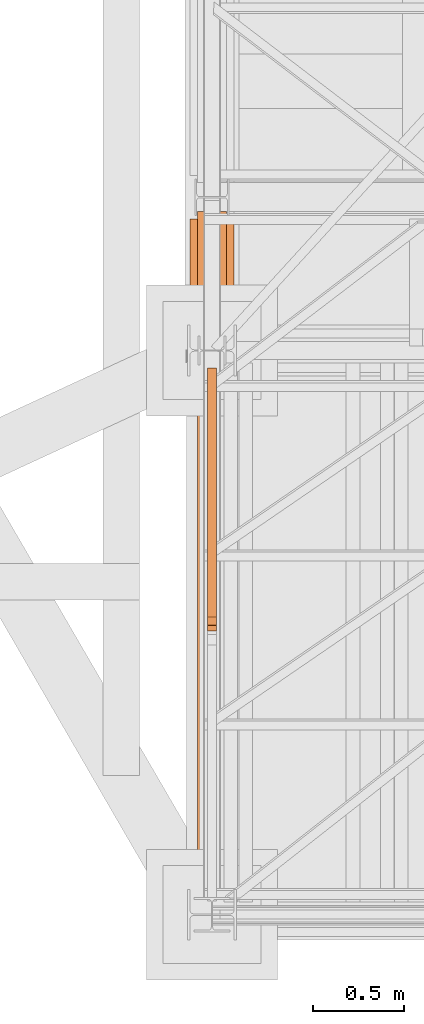
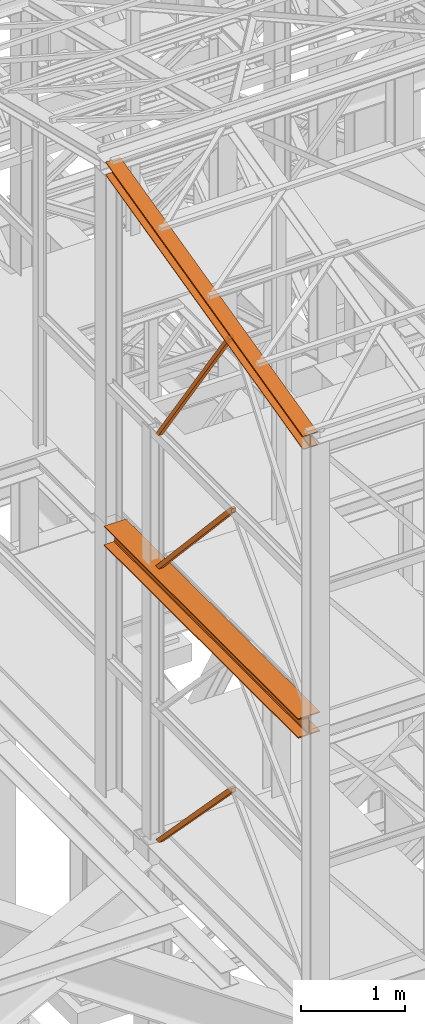
# One storey, part 12 of 208: 7 proxies.
"""IFC2X3 building model written with IfcOpenShell, lengths in millimetres."""

from ifc_helpers import new_model, entity, si_unit, converted_unit, frame, origin, origin_with_axes, place, context, subcontext, project, spatial, faceted_brep, element, save


model = new_model("IFC2X3")

# Units and contexts
model_context = context("Model", 3, precision=1e-05, world=origin())
plan_context = context("Plan", 3, precision=1e-05, world=origin())
body_context = subcontext(model_context, "Body", "Model", "MODEL_VIEW")
ifc_project = project(units=[si_unit("LENGTHUNIT", "METRE", prefix="MILLI"), converted_unit("PLANEANGLEUNIT", "DEGREE", entity("IfcPlaneAngleMeasure", 0.0174532925199433), si_unit("PLANEANGLEUNIT", "RADIAN"), dimensions=[0, 0, 0, 0, 0, 0, 0]), si_unit("AREAUNIT", "SQUARE_METRE"), si_unit("VOLUMEUNIT", "CUBIC_METRE")], contexts=[model_context, plan_context])

# Building, storey
building_placement = place(None, origin())
building = spatial("IfcBuilding", under=ifc_project, at=building_placement, CompositionType="COMPLEX")
storey_placement = place(building_placement, origin_with_axes())
storey = spatial("IfcBuildingStorey", under=building, at=storey_placement, Name="Geschoss", CompositionType="ELEMENT")

# Proxies
proxy_1_placement = place(storey_placement, frame((1078.254963760292, -25052.57438554952, 8254.989997913835), z_axis=(0.0, 0.0, 1.0), x_axis=(1.0, 0.0, 0.0)))
element("IfcBuildingElementProxy", 1, at=proxy_1_placement, inside=storey, context=body_context, shape_type="Brep", body=[
    faceted_brep([(240.0100095367423, 0.01000000000203727, 0.01000000000021828), (240.0100095367423, 3715.009990463259, 0.01000000000203727), (0.0100000000009004, 3715.009990463259, 0.01000000000021828), (0.009999999999990905, 0.01000000000203727, 0.01000000000021828), (0.009999999999990905, 0.01000000000203727, 0.01000000000021828), (0.0100000000009004, 3715.009990463259, 0.01000000000021828), (0.0100000000009004, 3715.009990463259, 12.0100019669535), (0.009999999999990905, 0.01000000000203727, 12.0100019669535), (0.009999999999990905, 0.01000000000203727, 12.0100019669535), (0.0100000000009004, 3715.009990463259, 12.0100019669535), (95.26000303983778, 3715.009990463259, 12.0100019669535), (95.26000303983687, 0.01000000000203727, 12.0100019669535), (95.26000303983687, 0.01000000000203727, 12.0100019669535), (95.26000303983778, 3715.009990463259, 12.0100019669535), (106.1284490099558, 3715.009990463259, 14.18530328035376), (106.1284490099549, 0.01000000000203727, 14.18530328035376), (106.1284490099549, 0.01000000000203727, 14.18530328035376), (106.1284490099558, 3715.009990463259, 14.18530328035376), (114.0846986493477, 3715.009990463259, 22.14155478239081), (114.0846986493468, 0.01000000000203727, 22.14155478239081), (114.0846986493468, 0.01000000000203727, 22.14155478239081), (114.0846986493477, 3715.009990463259, 22.14155478239081), (116.2600046193609, 3715.009990463259, 33.00999982118628), (116.26000461936, 0.01000000000203727, 33.00999982118628), (116.26000461936, 0.01000000000203727, 33.00999982118628), (116.2600046193609, 3715.009990463259, 33.00999982118628), (116.2600046193609, 3715.009990463259, 197.0100043511357), (116.26000461936, 0.01000000000203727, 197.0100043511357), (116.26000461936, 0.01000000000203727, 197.0100043511357), (116.2600046193609, 3715.009990463259, 197.0100043511357), (114.0846986493477, 3715.009990463259, 207.8784493899311), (114.0846986493468, 0.01000000000203727, 207.8784493899311), (114.0846986493468, 0.01000000000203727, 207.8784493899311), (114.0846986493477, 3715.009990463259, 207.8784493899311), (106.1284490099558, 3715.009990463259, 215.8347008919682), (106.1284490099549, 0.01000000000203727, 215.8347008919682), (106.1284490099549, 0.01000000000203727, 215.8347008919682), (106.1284490099558, 3715.009990463259, 215.8347008919682), (95.26000303983778, 3715.009990463259, 218.0100022053684), (95.26000303983778, 0.01000000000203727, 218.0100022053684), (95.26000303983778, 0.01000000000203727, 218.0100022053684), (95.26000303983778, 3715.009990463259, 218.0100022053684), (0.0100000000009004, 3715.009990463259, 218.0100022053684), (0.009999999999990905, 0.01000000000203727, 218.0100022053684), (0.009999999999990905, 0.01000000000203727, 218.0100022053684), (0.0100000000009004, 3715.009990463259, 218.0100022053684), (0.0100000000009004, 3715.009990463259, 230.0100041723235), (0.009999999999990905, 0.01000000000203727, 230.0100041723235), (0.009999999999990905, 0.01000000000203727, 230.0100041723235), (0.0100000000009004, 3715.009990463259, 230.0100041723235), (240.0100095367432, 3715.009990463259, 230.0100041723217), (240.0100095367423, 0.01000000000203727, 230.0100041723217), (240.0100095367423, 0.01000000000203727, 230.0100041723217), (240.0100095367432, 3715.009990463259, 230.0100041723217), (240.0100095367432, 3715.009990463259, 218.0100022053684), (240.0100095367423, 0.01000000000203727, 218.0100022053684), (240.0100095367423, 0.01000000000203727, 218.0100022053684), (240.0100095367432, 3715.009990463259, 218.0100022053684), (144.7600064969063, 3715.009990463259, 218.0100022053684), (144.7600064969054, 0.01000000000203727, 218.0100022053684), (144.7600064969054, 0.01000000000203727, 218.0100022053684), (144.7600064969063, 3715.009990463259, 218.0100022053684), (133.8915605267873, 3715.009990463259, 215.8347008919682), (133.8915605267873, 0.01000000000203727, 215.8347008919682), (133.8915605267873, 0.01000000000203727, 215.8347008919682), (133.8915605267873, 3715.009990463259, 215.8347008919682), (125.9353108873954, 3715.009990463259, 207.8784493899311), (125.9353108873954, 0.01000000000203727, 207.8784493899311), (125.9353108873954, 0.01000000000203727, 207.8784493899311), (125.9353108873954, 3715.009990463259, 207.8784493899311), (123.7600049173841, 3715.009990463259, 197.0100043511338), (123.7600049173823, 0.00999999999839929, 197.0100043511357), (123.7600049173823, 0.00999999999839929, 197.0100043511357), (123.7600049173841, 3715.009990463259, 197.0100043511338), (123.7600049173832, 3715.009990463259, 33.00999982118628), (123.7600049173823, 0.01000000000203727, 33.00999982118628), (123.7600049173823, 0.01000000000203727, 33.00999982118628), (123.7600049173832, 3715.009990463259, 33.00999982118628), (125.9353108873963, 3715.009990463259, 22.14155478239081), (125.9353108873954, 0.01000000000203727, 22.14155478239081), (125.9353108873954, 0.01000000000203727, 22.14155478239081), (125.9353108873963, 3715.009990463259, 22.14155478239081), (133.8915605267882, 3715.009990463259, 14.18530328035376), (133.8915605267873, 0.01000000000203727, 14.18530328035376), (133.8915605267873, 0.01000000000203727, 14.18530328035376), (133.8915605267882, 3715.009990463259, 14.18530328035376), (144.7600064969063, 3715.009990463259, 12.0100019669535), (144.7600064969054, 0.01000000000203727, 12.0100019669535), (144.7600064969054, 0.01000000000203727, 12.0100019669535), (144.7600064969063, 3715.009990463259, 12.0100019669535), (240.0100095367432, 3715.009990463259, 12.0100019669535), (240.0100095367423, 0.01000000000203727, 12.0100019669535), (240.0100095367423, 0.01000000000203727, 12.0100019669535), (240.0100095367432, 3715.009990463259, 12.0100019669535), (240.0100095367423, 3715.009990463259, 0.01000000000203727), (240.0100095367423, 0.01000000000203727, 0.01000000000021828), (0.009999999999990905, 0.01000000000203727, 0.01000000000021828), (0.009999999999990905, 0.01000000000203727, 12.0100019669535), (95.26000303983687, 0.01000000000203727, 12.0100019669535), (106.1284490099549, 0.01000000000203727, 14.18530328035376), (114.0846986493468, 0.01000000000203727, 22.14155478239081), (116.26000461936, 0.01000000000203727, 33.00999982118628), (116.26000461936, 0.01000000000203727, 197.0100043511357), (114.0846986493468, 0.01000000000203727, 207.8784493899311), (106.1284490099549, 0.01000000000203727, 215.8347008919682), (95.26000303983778, 0.01000000000203727, 218.0100022053684), (0.009999999999990905, 0.01000000000203727, 218.0100022053684), (0.009999999999990905, 0.01000000000203727, 230.0100041723235), (240.0100095367423, 0.01000000000203727, 230.0100041723217), (240.0100095367423, 0.01000000000203727, 218.0100022053684), (144.7600064969054, 0.01000000000203727, 218.0100022053684), (133.8915605267873, 0.01000000000203727, 215.8347008919682), (125.9353108873954, 0.01000000000203727, 207.8784493899311), (123.7600049173823, 0.00999999999839929, 197.0100043511357), (123.7600049173823, 0.01000000000203727, 33.00999982118628), (125.9353108873954, 0.01000000000203727, 22.14155478239081), (133.8915605267873, 0.01000000000203727, 14.18530328035376), (144.7600064969054, 0.01000000000203727, 12.0100019669535), (240.0100095367423, 0.01000000000203727, 12.0100019669535), (240.0100095367423, 0.01000000000203727, 0.01000000000021828), (0.0100000000009004, 3715.009990463259, 0.01000000000021828), (240.0100095367423, 3715.009990463259, 0.01000000000203727), (240.0100095367432, 3715.009990463259, 12.0100019669535), (144.7600064969063, 3715.009990463259, 12.0100019669535), (133.8915605267882, 3715.009990463259, 14.18530328035376), (125.9353108873963, 3715.009990463259, 22.14155478239081), (123.7600049173832, 3715.009990463259, 33.00999982118628), (123.7600049173841, 3715.009990463259, 197.0100043511338), (125.9353108873954, 3715.009990463259, 207.8784493899311), (133.8915605267873, 3715.009990463259, 215.8347008919682), (144.7600064969063, 3715.009990463259, 218.0100022053684), (240.0100095367432, 3715.009990463259, 218.0100022053684), (240.0100095367432, 3715.009990463259, 230.0100041723217), (0.0100000000009004, 3715.009990463259, 230.0100041723235), (0.0100000000009004, 3715.009990463259, 218.0100022053684), (95.26000303983778, 3715.009990463259, 218.0100022053684), (106.1284490099558, 3715.009990463259, 215.8347008919682), (114.0846986493477, 3715.009990463259, 207.8784493899311), (116.2600046193609, 3715.009990463259, 197.0100043511357), (116.2600046193609, 3715.009990463259, 33.00999982118628), (114.0846986493477, 3715.009990463259, 22.14155478239081), (106.1284490099558, 3715.009990463259, 14.18530328035376), (95.26000303983778, 3715.009990463259, 12.0100019669535), (0.0100000000009004, 3715.009990463259, 12.0100019669535)], [[[0, 1, 2, 3]], [[4, 5, 6, 7]], [[8, 9, 10, 11]], [[12, 13, 14, 15]], [[16, 17, 18, 19]], [[20, 21, 22, 23]], [[24, 25, 26, 27]], [[28, 29, 30, 31]], [[32, 33, 34, 35]], [[36, 37, 38, 39]], [[40, 41, 42, 43]], [[44, 45, 46, 47]], [[48, 49, 50, 51]], [[52, 53, 54, 55]], [[56, 57, 58, 59]], [[60, 61, 62, 63]], [[64, 65, 66, 67]], [[68, 69, 70, 71]], [[72, 73, 74, 75]], [[76, 77, 78, 79]], [[80, 81, 82, 83]], [[84, 85, 86, 87]], [[88, 89, 90, 91]], [[92, 93, 94, 95]], [[96, 97, 98, 99, 100, 101, 102, 103, 104, 105, 106, 107, 108, 109, 110, 111, 112, 113, 114, 115, 116, 117, 118, 119]], [[120, 121, 122, 123, 124, 125, 126, 127, 128, 129, 130, 131, 132, 133, 134, 135, 136, 137, 138, 139, 140, 141, 142, 143]]], orient=[[False], [False], [False], [False], [False], [False], [False], [False], [False], [False], [False], [False], [False], [False], [False], [False], [False], [False], [False], [False], [False], [False], [False], [False], [False], [False]]),
])
proxy_2_placement = place(storey_placement, frame((1118.254966591503, -25077.57437538435, 11628.70515179705), z_axis=(0.0, 0.0, 1.0), x_axis=(1.0, 0.0, 0.0)))
element("IfcBuildingElementProxy", 2, at=proxy_2_placement, inside=storey, context=body_context, shape_type="Brep", body=[
    faceted_brep([(160.0100113248898, 3780.009979404025, 1074.775244917653), (160.0100113248795, 0.00999999999839929, 156.4315054631916), (0.009999999999990905, 0.00999999999839929, 156.4315054631916), (0.01000000000681212, 3780.009979404025, 1074.775244917653), (0.01000000000681212, 3780.009979404025, 1074.775244917653), (0.009999999999990905, 0.00999999999839929, 156.4315054631916), (0.009999999999990905, 0.00999999999839929, 147.1697029728093), (0.01000000000681212, 3780.009979404025, 1065.513442427271), (0.01000000000681212, 3780.009979404025, 1065.513442427271), (0.009999999999990905, 0.00999999999839929, 147.1697029728093), (62.01000457465648, 0.00999999999839929, 147.1697029728093), (62.01000457466284, 3780.009979404025, 1065.513442427271), (62.01000457466284, 3780.009979404025, 1065.513442427271), (62.01000457465648, 0.00999999999839929, 147.1697029728093), (69.77318079977863, 0.00999999999839929, 145.5707163655079), (69.77318079978863, 3780.009979404025, 1063.914455819968), (69.77318079978863, 3780.009979404025, 1063.914455819968), (69.77318079977863, 0.00999999999839929, 145.5707163655079), (75.45621545821064, 0.00999999999839929, 139.7223691397903), (75.4562154582211, 3780.009979404025, 1058.066108594254), (75.4562154582211, 3780.009979404025, 1058.066108594254), (75.45621545821064, 0.00999999999839929, 139.7223691397903), (77.01000563636057, 0.00999999999839929, 131.7333744340358), (77.01000563637058, 3780.009979404025, 1050.077113888498), (77.01000563637058, 3780.009979404025, 1050.077113888498), (77.01000563636057, 0.00999999999839929, 131.7333744340358), (77.01000563636057, 0.00999999999839929, 24.70813486281259), (77.01000563637058, 3780.009979404025, 943.0518743172743), (77.01000563637058, 3780.009979404025, 943.0518743172743), (77.01000563636057, 0.00999999999839929, 24.70813486281259), (75.45621545821064, 0.00999999999839929, 16.71913632339965), (75.45621545822064, 3780.009979404025, 935.0628757778613), (75.45621545822064, 3780.009979404025, 935.0628757778613), (75.45621545821064, 0.00999999999839929, 16.71913632339965), (69.77318079977863, 0.00999999999839929, 10.87078909768752), (69.77318079978863, 3780.009979404025, 929.2145285521474), (69.77318079978863, 3780.009979404025, 929.2145285521474), (69.77318079977863, 0.00999999999839929, 10.87078909768752), (62.01000457465284, 0.00999999999839929, 9.27180249038247), (62.01000457466284, 3780.009979404025, 927.6155419448442), (62.01000457466284, 3780.009979404025, 927.6155419448442), (62.01000457465284, 0.00999999999839929, 9.27180249038247), (0.009999999999990905, 0.00999999999839929, 9.27180249038247), (0.01000000000681212, 3780.009979404025, 927.6155419448423), (0.01000000000681212, 3780.009979404025, 927.6155419448423), (0.009999999999990905, 0.00999999999839929, 9.27180249038247), (0.009999999999990905, 0.00999999999839929, 0.01000000000021828), (0.01000000000635737, 3780.009979404025, 918.3537394544601), (0.01000000000635737, 3780.009979404025, 918.3537394544601), (0.009999999999990905, 0.00999999999839929, 0.01000000000021828), (160.0100113248827, 0.00999999999839929, 0.01000000000021828), (160.0100113248898, 3780.009979404025, 918.3537394544619), (160.0100113248898, 3780.009979404025, 918.3537394544619), (160.0100113248827, 0.00999999999839929, 0.01000000000021828), (160.0100113248832, 0.00999999999839929, 9.27180249038065), (160.0100113248898, 3780.009979404025, 927.6155419448423), (160.0100113248898, 3780.009979404025, 927.6155419448423), (160.0100113248832, 0.00999999999839929, 9.27180249038065), (98.01000675022237, 0.00999999999839929, 9.27180249038247), (98.01000675023238, 3780.009979404025, 927.6155419448423), (98.01000675023238, 3780.009979404025, 927.6155419448423), (98.01000675022237, 0.00999999999839929, 9.27180249038247), (90.24683052509658, 0.00999999999839929, 10.87078909768752), (90.24683052510659, 3780.009979404025, 929.2145285521474), (90.24683052510659, 3780.009979404025, 929.2145285521474), (90.24683052509658, 0.00999999999839929, 10.87078909768752), (84.56379586666458, 0.00999999999839929, 16.71913632339783), (84.56379586667458, 3780.009979404025, 935.0628757778613), (84.56379586667458, 3780.009979404025, 935.0628757778613), (84.56379586666458, 0.00999999999839929, 16.71913632339783), (83.01000568851464, 0.00999999999839929, 24.70813486281077), (83.01000568852464, 3780.009979404025, 943.0518743172743), (83.01000568852464, 3780.009979404025, 943.0518743172743), (83.01000568851464, 0.00999999999839929, 24.70813486281077), (83.0100056885151, 0.00999999999839929, 131.733374434034), (83.01000568852464, 3780.009979404025, 1050.077113888496), (83.01000568852464, 3780.009979404025, 1050.077113888496), (83.0100056885151, 0.00999999999839929, 131.733374434034), (84.56379586666458, 0.00999999999839929, 139.7223691397903), (84.56379586667504, 3780.009979404025, 1058.066108594254), (84.56379586667504, 3780.009979404025, 1058.066108594254), (84.56379586666458, 0.00999999999839929, 139.7223691397903), (90.24683052509704, 0.00999999999839929, 145.5707163655079), (90.24683052510704, 3780.009979404025, 1063.914455819968), (90.24683052510704, 3780.009979404025, 1063.914455819968), (90.24683052509704, 0.00999999999839929, 145.5707163655079), (98.01000675022237, 0.00999999999839929, 147.1697029728093), (98.01000675023238, 3780.009979404025, 1065.513442427271), (98.01000675023238, 3780.009979404025, 1065.513442427271), (98.01000675022237, 0.00999999999839929, 147.1697029728093), (160.010011324883, 0.00999999999839929, 147.1697029728093), (160.0100113248898, 3780.009979404025, 1065.513442427271), (160.0100113248898, 3780.009979404025, 1065.513442427271), (160.010011324883, 0.00999999999839929, 147.1697029728093), (160.0100113248795, 0.00999999999839929, 156.4315054631916), (160.0100113248898, 3780.009979404025, 1074.775244917653), (0.01000000000681212, 3780.009979404025, 1074.775244917653), (0.01000000000681212, 3780.009979404025, 1065.513442427271), (62.01000457466284, 3780.009979404025, 1065.513442427271), (69.77318079978863, 3780.009979404025, 1063.914455819968), (75.4562154582211, 3780.009979404025, 1058.066108594254), (77.01000563637058, 3780.009979404025, 1050.077113888498), (77.01000563637058, 3780.009979404025, 943.0518743172743), (75.45621545822064, 3780.009979404025, 935.0628757778613), (69.77318079978863, 3780.009979404025, 929.2145285521474), (62.01000457466284, 3780.009979404025, 927.6155419448442), (0.01000000000681212, 3780.009979404025, 927.6155419448423), (0.01000000000635737, 3780.009979404025, 918.3537394544601), (160.0100113248898, 3780.009979404025, 918.3537394544619), (160.0100113248898, 3780.009979404025, 927.6155419448423), (98.01000675023238, 3780.009979404025, 927.6155419448423), (90.24683052510659, 3780.009979404025, 929.2145285521474), (84.56379586667458, 3780.009979404025, 935.0628757778613), (83.01000568852464, 3780.009979404025, 943.0518743172743), (83.01000568852464, 3780.009979404025, 1050.077113888496), (84.56379586667504, 3780.009979404025, 1058.066108594254), (90.24683052510704, 3780.009979404025, 1063.914455819968), (98.01000675023238, 3780.009979404025, 1065.513442427271), (160.0100113248898, 3780.009979404025, 1065.513442427271), (160.0100113248898, 3780.009979404025, 1074.775244917653), (160.0100113248795, 0.00999999999839929, 156.4315054631916), (160.010011324883, 0.00999999999839929, 147.1697029728093), (98.01000675022237, 0.00999999999839929, 147.1697029728093), (90.24683052509704, 0.00999999999839929, 145.5707163655079), (84.56379586666458, 0.00999999999839929, 139.7223691397903), (83.0100056885151, 0.00999999999839929, 131.733374434034), (83.01000568851464, 0.00999999999839929, 24.70813486281077), (84.56379586666458, 0.00999999999839929, 16.71913632339783), (90.24683052509658, 0.00999999999839929, 10.87078909768752), (98.01000675022237, 0.00999999999839929, 9.27180249038247), (160.0100113248832, 0.00999999999839929, 9.27180249038065), (160.0100113248827, 0.00999999999839929, 0.01000000000021828), (0.009999999999990905, 0.00999999999839929, 0.01000000000021828), (0.009999999999990905, 0.00999999999839929, 9.27180249038247), (62.01000457465284, 0.00999999999839929, 9.27180249038247), (69.77318079977863, 0.00999999999839929, 10.87078909768752), (75.45621545821064, 0.00999999999839929, 16.71913632339965), (77.01000563636057, 0.00999999999839929, 24.70813486281259), (77.01000563636057, 0.00999999999839929, 131.7333744340358), (75.45621545821064, 0.00999999999839929, 139.7223691397903), (69.77318079977863, 0.00999999999839929, 145.5707163655079), (62.01000457465648, 0.00999999999839929, 147.1697029728093), (0.009999999999990905, 0.00999999999839929, 147.1697029728093), (0.009999999999990905, 0.00999999999839929, 156.4315054631916)], [[[0, 1, 2, 3]], [[4, 5, 6, 7]], [[8, 9, 10, 11]], [[12, 13, 14, 15]], [[16, 17, 18, 19]], [[20, 21, 22, 23]], [[24, 25, 26, 27]], [[28, 29, 30, 31]], [[32, 33, 34, 35]], [[36, 37, 38, 39]], [[40, 41, 42, 43]], [[44, 45, 46, 47]], [[48, 49, 50, 51]], [[52, 53, 54, 55]], [[56, 57, 58, 59]], [[60, 61, 62, 63]], [[64, 65, 66, 67]], [[68, 69, 70, 71]], [[72, 73, 74, 75]], [[76, 77, 78, 79]], [[80, 81, 82, 83]], [[84, 85, 86, 87]], [[88, 89, 90, 91]], [[92, 93, 94, 95]], [[96, 97, 98, 99, 100, 101, 102, 103, 104, 105, 106, 107, 108, 109, 110, 111, 112, 113, 114, 115, 116, 117, 118, 119]], [[120, 121, 122, 123, 124, 125, 126, 127, 128, 129, 130, 131, 132, 133, 134, 135, 136, 137, 138, 139, 140, 141, 142, 143]]], orient=[[False], [False], [False], [False], [False], [False], [False], [False], [False], [False], [False], [False], [False], [False], [False], [False], [False], [False], [False], [False], [False], [False], [False], [False], [False], [False]]),
])
proxy_3_placement = place(storey_placement, frame((1173.25497001878, -23609.99467518261, 5284.990005364415), z_axis=(0.0, 0.0, 1.0), x_axis=(1.0, 0.0, 0.0)))
element("IfcBuildingElementProxy", 3, at=proxy_3_placement, inside=storey, context=body_context, shape_type="Brep", body=[
    faceted_brep([(0.0100000000009004, 0.2928158898466791, 1428.866375912856), (50.01000074505896, 0.2928158898466791, 1428.866375912854), (50.01000074505805, 1388.6428749638, 0.01000000000021828), (0.009999999999990905, 1388.6428749638, 0.01000000000021828), (50.01000074505896, 32.15127611343269, 1474.917439180826), (50.01000074505805, 1452.430287281288, 0.01000000000021828), (50.01000074505805, 1388.6428749638, 0.01000000000021828), (50.01000074505896, 0.2928158898466791, 1428.866375912854), (50.01000074505896, 0.00999999999839929, 1475.009993890528), (0.0100000000009004, 32.15127611343269, 1474.917439180826), (0.009999999999990905, 1452.430287281288, 0.01000000000021828), (50.01000074505805, 1452.430287281288, 0.01000000000021828), (50.01000074505896, 32.15127611343269, 1474.917439180826), (0.0100000000009004, 0.00999999999839929, 1475.009993890528), (0.0100000000009004, 0.2928158898466791, 1428.866375912856), (0.009999999999990905, 1388.6428749638, 0.01000000000021828), (0.009999999999990905, 1452.430287281288, 0.01000000000021828), (0.0100000000009004, 32.15127611343269, 1474.917439180826), (50.01000074505896, 0.00999999999839929, 1475.009993890528), (0.0100000000009004, 0.00999999999839929, 1475.009993890528), (0.0100000000009004, 32.15127611343269, 1474.917439180826), (50.01000074505896, 32.15127611343269, 1474.917439180826), (50.01000074505896, 0.2928158898466791, 1428.866375912854), (0.0100000000009004, 0.2928158898466791, 1428.866375912856), (0.0100000000009004, 0.00999999999839929, 1475.009993890528), (50.01000074505896, 0.00999999999839929, 1475.009993890528), (0.009999999999990905, 1388.6428749638, 0.01000000000021828), (50.01000074505805, 1388.6428749638, 0.01000000000021828), (50.01000074505805, 1452.430287281288, 0.01000000000021828), (0.009999999999990905, 1452.430287281288, 0.01000000000021828)], [[[0, 1, 2, 3]], [[4, 5, 6, 7, 8]], [[9, 10, 11, 12]], [[13, 14, 15, 16, 17]], [[18, 19, 20, 21]], [[22, 23, 24, 25]], [[26, 27, 28, 29]]], orient=[[False], [False], [False], [False], [False], [False], [False]]),
])
proxy_4_placement = place(storey_placement, frame((1173.254970018778, -23609.75807774477, 8484.990002086159), z_axis=(0.0, 0.0, 1.0), x_axis=(1.0, 0.0, 0.0)))
element("IfcBuildingElementProxy", 4, at=proxy_4_placement, inside=storey, context=body_context, shape_type="Brep", body=[
    faceted_brep([(0.0100000000009004, 0.00999999999839929, 1497.729951931144), (50.01000074505896, 0.00999999999839929, 1497.72995193114), (50.01000074505805, 1388.406277525959, 0.00999999999839929), (0.009999999999990905, 1388.406277525959, 0.00999999999839929), (50.01000074505896, 31.9146786755955, 1542.509998658894), (50.01000074505805, 1452.193689843447, 0.00999999999839929), (50.01000074505805, 1388.406277525959, 0.00999999999839929), (50.01000074505896, 0.00999999999839929, 1497.72995193114), (50.01000074505896, 0.1938854341788101, 1542.602553368595), (0.0100000000009004, 31.9146786755955, 1542.509998658894), (0.009999999999990905, 1452.193689843447, 0.00999999999839929), (50.01000074505805, 1452.193689843447, 0.00999999999839929), (50.01000074505896, 31.9146786755955, 1542.509998658894), (0.0100000000009004, 0.1938854341788101, 1542.602553368595), (0.0100000000009004, 0.00999999999839929, 1497.729951931144), (0.009999999999990905, 1388.406277525959, 0.00999999999839929), (0.009999999999990905, 1452.193689843447, 0.00999999999839929), (0.0100000000009004, 31.9146786755955, 1542.509998658894), (50.01000074505896, 0.1938854341788101, 1542.602553368595), (0.0100000000009004, 0.1938854341788101, 1542.602553368595), (0.0100000000009004, 31.9146786755955, 1542.509998658894), (50.01000074505896, 31.9146786755955, 1542.509998658894), (50.01000074505896, 0.00999999999839929, 1497.72995193114), (0.0100000000009004, 0.00999999999839929, 1497.729951931144), (0.0100000000009004, 0.1938854341788101, 1542.602553368595), (50.01000074505896, 0.1938854341788101, 1542.602553368595), (0.009999999999990905, 1388.406277525959, 0.00999999999839929), (50.01000074505805, 1388.406277525959, 0.00999999999839929), (50.01000074505805, 1452.193689843447, 0.00999999999839929), (0.009999999999990905, 1452.193689843447, 0.00999999999839929)], [[[0, 1, 2, 3]], [[4, 5, 6, 7, 8]], [[9, 10, 11, 12]], [[13, 14, 15, 16, 17]], [[18, 19, 20, 21]], [[22, 23, 24, 25]], [[26, 27, 28, 29]]], orient=[[False], [False], [False], [False], [False], [False], [False]]),
])
proxy_5_placement = place(storey_placement, frame((1173.254970018778, -23609.75807774477, 8484.990002086159), z_axis=(0.0, 0.0, 1.0), x_axis=(1.0, 0.0, 0.0)))
element("IfcBuildingElementProxy", 5, at=proxy_5_placement, inside=storey, context=body_context, shape_type="Brep", body=[
    faceted_brep([(0.0100000000009004, 0.00999999999839929, 1497.729951931144), (50.01000074505896, 0.00999999999839929, 1497.72995193114), (50.01000074505805, 1388.406277525959, 0.00999999999839929), (0.009999999999990905, 1388.406277525959, 0.00999999999839929), (50.01000074505896, 31.9146786755955, 1542.509998658894), (50.01000074505805, 1452.193689843447, 0.00999999999839929), (50.01000074505805, 1388.406277525959, 0.00999999999839929), (50.01000074505896, 0.00999999999839929, 1497.72995193114), (50.01000074505896, 0.1938854341788101, 1542.602553368595), (0.0100000000009004, 31.9146786755955, 1542.509998658894), (0.009999999999990905, 1452.193689843447, 0.00999999999839929), (50.01000074505805, 1452.193689843447, 0.00999999999839929), (50.01000074505896, 31.9146786755955, 1542.509998658894), (0.0100000000009004, 0.1938854341788101, 1542.602553368595), (0.0100000000009004, 0.00999999999839929, 1497.729951931144), (0.009999999999990905, 1388.406277525959, 0.00999999999839929), (0.009999999999990905, 1452.193689843447, 0.00999999999839929), (0.0100000000009004, 31.9146786755955, 1542.509998658894), (50.01000074505896, 0.1938854341788101, 1542.602553368595), (0.0100000000009004, 0.1938854341788101, 1542.602553368595), (0.0100000000009004, 31.9146786755955, 1542.509998658894), (50.01000074505896, 31.9146786755955, 1542.509998658894), (50.01000074505896, 0.00999999999839929, 1497.72995193114), (0.0100000000009004, 0.00999999999839929, 1497.729951931144), (0.0100000000009004, 0.1938854341788101, 1542.602553368595), (50.01000074505896, 0.1938854341788101, 1542.602553368595), (0.009999999999990905, 1388.406277525959, 0.00999999999839929), (50.01000074505805, 1388.406277525959, 0.00999999999839929), (50.01000074505805, 1452.193689843447, 0.00999999999839929), (0.009999999999990905, 1452.193689843447, 0.00999999999839929)], [[[0, 1, 2, 3]], [[4, 5, 6, 7, 8]], [[9, 10, 11, 12]], [[13, 14, 15, 16, 17]], [[18, 19, 20, 21]], [[22, 23, 24, 25]], [[26, 27, 28, 29]]], orient=[[False], [False], [False], [False], [False], [False], [False]]),
])
for number, where, z_axis, x_axis in (
    (6, (1173.254970018778, -23575.83452420606, 10032.49000074505), (0.0, 0.0, 1.0), (1.0, 0.0, 0.0)),
    (7, (1173.254970018778, -23575.83452420606, 10032.49000074505), (0.0, 0.0, 1.0), (1.0, 0.0, 0.0)),
):
    element("IfcBuildingElementProxy", number, at=place(storey_placement, frame(where, z_axis=z_axis, x_axis=x_axis)), inside=storey, context=body_context, shape_type="Brep", body=[
        faceted_brep([(50.01000074505896, 1418.270136304735, 0.00999999999839929), (50.01000074505805, 44.61965619294278, 1971.847245483068), (0.009999999999990905, 44.61965619294278, 1971.847245483068), (0.0100000000009004, 1418.270136304735, 0.00999999999839929), (50.01000074505896, 1368.278645494167, 0.00999999999839929), (50.01000074505805, 0.00999999999839929, 1961.019111489331), (50.01000074505805, 44.61965619294278, 1971.847245483068), (50.01000074505896, 1418.270136304735, 0.00999999999839929), (0.0100000000009004, 1368.278645494167, 0.00999999999839929), (0.009999999999990905, 0.00999999999839929, 1961.01911148933), (50.01000074505805, 0.00999999999839929, 1961.019111489331), (50.01000074505896, 1368.278645494167, 0.00999999999839929), (0.0100000000009004, 1418.270136304735, 0.00999999999839929), (0.009999999999990905, 44.61965619294278, 1971.847245483068), (0.009999999999990905, 0.00999999999839929, 1961.01911148933), (0.0100000000009004, 1368.278645494167, 0.00999999999839929), (0.0100000000009004, 1418.270136304735, 0.00999999999839929), (0.0100000000009004, 1368.278645494167, 0.00999999999839929), (50.01000074505896, 1368.278645494167, 0.00999999999839929), (50.01000074505896, 1418.270136304735, 0.00999999999839929), (50.01000074505805, 44.61965619294278, 1971.847245483068), (50.01000074505805, 0.00999999999839929, 1961.019111489331), (0.009999999999990905, 0.00999999999839929, 1961.01911148933), (0.009999999999990905, 44.61965619294278, 1971.847245483068)], [[[0, 1, 2, 3]], [[4, 5, 6, 7]], [[8, 9, 10, 11]], [[12, 13, 14, 15]], [[16, 17, 18, 19]], [[20, 21, 22, 23]]], orient=[[False], [False], [False], [False], [False], [False]]),
    ])

save(model, "model.ifc")
